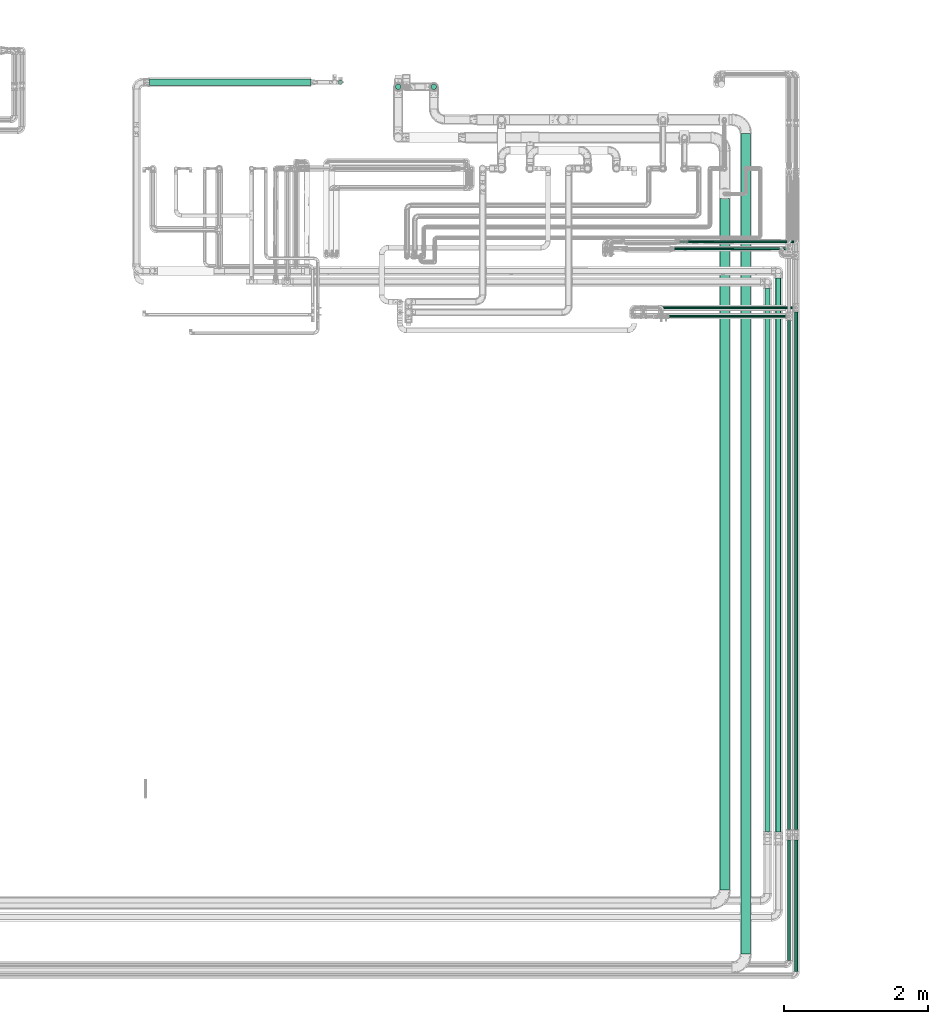
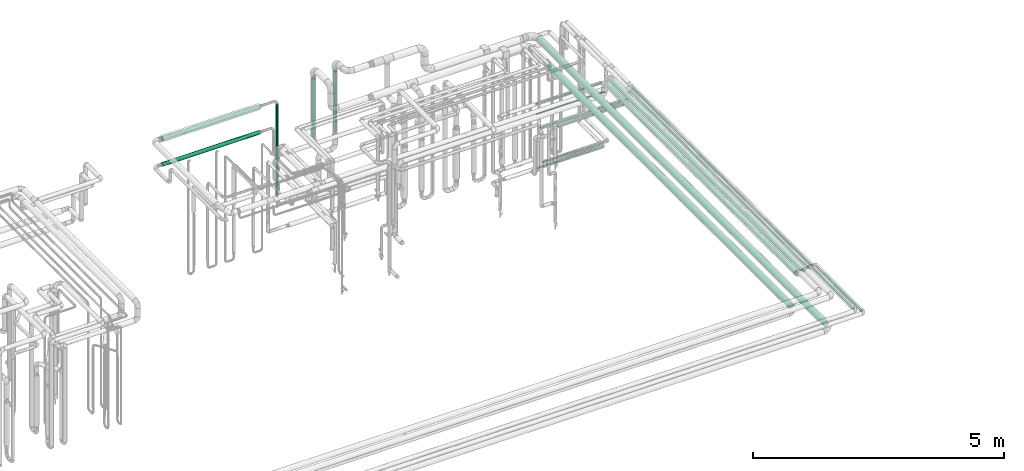
# One storey, part 543 of 827: 19 flow segments.
"""IFC2X3 building model written with IfcOpenShell, lengths in millimetres."""

from ifc_helpers import new_model, entity, si_unit, converted_unit, derived_unit, direction, frame, origin, origin_2d_with_axis, place, context, subcontext, project, spatial, polyline, circle, outline, extrude, type_object, element, save


model = new_model("IFC2X3")

# Units and contexts
model_context = context("Model", 3, precision=0.01, world=origin(), true_north=direction((6.12303176911189e-17, 1.0)))
body_context = subcontext(model_context, "Body", "Model", "MODEL_VIEW")
ifc_project = project(units=[si_unit("LENGTHUNIT", "METRE", prefix="MILLI"), si_unit("AREAUNIT", "SQUARE_METRE"), si_unit("VOLUMEUNIT", "CUBIC_METRE"), converted_unit("PLANEANGLEUNIT", "DEGREE", entity("IfcRatioMeasure", 0.0174532925199433), si_unit("PLANEANGLEUNIT", "RADIAN"), dimensions=[0, 0, 0, 0, 0, 0, 0]), si_unit("MASSUNIT", "GRAM", prefix="KILO"), derived_unit("MASSDENSITYUNIT", [(si_unit("MASSUNIT", "GRAM", prefix="KILO"), 1), (si_unit("LENGTHUNIT", "METRE"), -3)]), derived_unit("MOMENTOFINERTIAUNIT", [(si_unit("LENGTHUNIT", "METRE"), 4)]), si_unit("TIMEUNIT", "SECOND"), si_unit("FREQUENCYUNIT", "HERTZ"), si_unit("THERMODYNAMICTEMPERATUREUNIT", "DEGREE_CELSIUS"), derived_unit("THERMALTRANSMITTANCEUNIT", [(si_unit("MASSUNIT", "GRAM", prefix="KILO"), 1), (si_unit("THERMODYNAMICTEMPERATUREUNIT", "KELVIN"), -1), (si_unit("TIMEUNIT", "SECOND"), -3)]), derived_unit("VOLUMETRICFLOWRATEUNIT", [(si_unit("LENGTHUNIT", "METRE"), 3), (si_unit("TIMEUNIT", "SECOND"), -1)]), derived_unit("MASSFLOWRATEUNIT", [(si_unit("MASSUNIT", "GRAM", prefix="KILO"), 1), (si_unit("TIMEUNIT", "SECOND"), -1)]), derived_unit("ROTATIONALFREQUENCYUNIT", [(si_unit("TIMEUNIT", "SECOND"), -1)]), si_unit("ELECTRICCURRENTUNIT", "AMPERE"), si_unit("ELECTRICVOLTAGEUNIT", "VOLT"), si_unit("POWERUNIT", "WATT"), si_unit("FORCEUNIT", "NEWTON", prefix="KILO"), si_unit("ILLUMINANCEUNIT", "LUX"), si_unit("LUMINOUSFLUXUNIT", "LUMEN"), si_unit("LUMINOUSINTENSITYUNIT", "CANDELA"), derived_unit("USERDEFINED", [(si_unit("MASSUNIT", "GRAM", prefix="KILO"), -1), (si_unit("LENGTHUNIT", "METRE"), -2), (si_unit("TIMEUNIT", "SECOND"), 3), (si_unit("LUMINOUSFLUXUNIT", "LUMEN"), 1)]), derived_unit("LINEARVELOCITYUNIT", [(si_unit("LENGTHUNIT", "METRE"), 1), (si_unit("TIMEUNIT", "SECOND"), -1)]), si_unit("PRESSUREUNIT", "PASCAL"), derived_unit("USERDEFINED", [(si_unit("LENGTHUNIT", "METRE"), -2), (si_unit("MASSUNIT", "GRAM", prefix="KILO"), 1), (si_unit("TIMEUNIT", "SECOND"), -2)]), derived_unit("LINEARFORCEUNIT", [(si_unit("MASSUNIT", "GRAM", prefix="KILO"), 1), (si_unit("LENGTHUNIT", "METRE"), 1), (si_unit("TIMEUNIT", "SECOND"), -2), (si_unit("LENGTHUNIT", "METRE"), -1)]), derived_unit("PLANARFORCEUNIT", [(si_unit("MASSUNIT", "GRAM", prefix="KILO"), 1), (si_unit("LENGTHUNIT", "METRE"), 1), (si_unit("TIMEUNIT", "SECOND"), -2), (si_unit("LENGTHUNIT", "METRE"), -2)])], contexts=[model_context])

# Site, building, storey
site_placement = place(None, origin())
site = spatial("IfcSite", under=ifc_project, at=site_placement, CompositionType="ELEMENT")
building_placement = place(site_placement, origin())
building = spatial("IfcBuilding", under=site, at=building_placement, CompositionType="ELEMENT")
storey_placement = place(building_placement, frame((0.0, 0.0, 28200.0)))
storey = spatial("IfcBuildingStorey", under=building, at=storey_placement, Name="08", CompositionType="ELEMENT", Elevation=28200.0)

# Flow segments
pipe_segment_type_1 = type_object("IfcPipeSegmentType", PredefinedType="NOTDEFINED")
flow_segment_1_placement = place(storey_placement, frame((60382.95, 6565.0, 2831.9)))
element("IfcFlowSegment", 1, at=flow_segment_1_placement, inside=storey, type_object=pipe_segment_type_1, context=body_context, shape_type="SweptSolid", body=[
    extrude(circle(Radius=66.5, at=origin_2d_with_axis()), frame((68.1, 0.0, 68.1), z_axis=(0.0, 1.0, 0.0), x_axis=(-1.0, 0.0, 0.0)), (0.0, 0.0, 1.0), 11425.0955266224),
])
flow_segment_2_placement = place(storey_placement, frame((60090.45, 7456.2, 2831.87)))
element("IfcFlowSegment", 2, at=flow_segment_2_placement, inside=storey, type_object=pipe_segment_type_1, context=body_context, shape_type="SweptSolid", body=[
    extrude(circle(Radius=66.5, at=origin_2d_with_axis()), frame((68.1, 0.0, 68.1), z_axis=(0.0, 1.0, 0.0), x_axis=(-1.0, 0.0, 0.0)), (0.0, 0.0, 1.0), 9626.5836518491),
])
flow_segment_3_placement = place(storey_placement, frame((56068.95, 18596.39, 1800.0)))
element("IfcFlowSegment", 3, at=flow_segment_3_placement, inside=storey, type_object=pipe_segment_type_1, context=body_context, shape_type="SweptSolid", body=[
    extrude(circle(Radius=38.0, at=origin_2d_with_axis()), frame((39.6, 39.6, 0.0)), (0.0, 0.0, 1.0), 1469.74318880571),
])
flow_segment_4_placement = place(storey_placement, frame((55571.45, 18596.39, 1843.17)))
element("IfcFlowSegment", 4, at=flow_segment_4_placement, inside=storey, type_object=pipe_segment_type_1, context=body_context, shape_type="SweptSolid", body=[
    extrude(circle(Radius=38.0, at=origin_2d_with_axis()), frame((39.6, 39.6, 0.0)), (0.0, 0.0, 1.0), 1426.57392214822),
])
pipe_segment_type_2 = type_object("IfcPipeSegmentType", PredefinedType="NOTDEFINED")
flow_segment_5_placement = place(storey_placement, frame((61127.04, 8300.34, 2974.15)))
element("IfcFlowSegment", 5, at=flow_segment_5_placement, inside=storey, type_object=pipe_segment_type_2, context=body_context, shape_type="SweptSolid", body=[
    extrude(circle(Radius=24.0, at=origin_2d_with_axis()), frame((25.6, 0.0, 25.6), z_axis=(0.0, 1.0, 0.0), x_axis=(-1.0, 0.0, 0.0)), (0.0, 0.0, 1.0), 7203.18637121827),
])
flow_segment_6_placement = place(storey_placement, frame((61027.04, 8301.25, 2974.15)))
element("IfcFlowSegment", 6, at=flow_segment_6_placement, inside=storey, type_object=pipe_segment_type_2, context=body_context, shape_type="SweptSolid", body=[
    extrude(circle(Radius=24.0, at=origin_2d_with_axis()), frame((25.6, 0.0, 25.6), z_axis=(0.0, 1.0, 0.0), x_axis=(-1.0, 0.0, 0.0)), (0.0, 0.0, 1.0), 7085.96306405012),
])
flow_segment_7_placement = place(storey_placement, frame((59460.44, 16364.84, 2635.0)))
element("IfcFlowSegment", 7, at=flow_segment_7_placement, inside=storey, type_object=pipe_segment_type_2, context=body_context, shape_type="SweptSolid", body=[
    extrude(circle(Radius=13.4, at=origin_2d_with_axis()), frame((0.0, 15.0, 15.0), z_axis=(1.0, 0.0, 0.0), x_axis=(0.0, 1.0, 0.0)), (0.0, 0.0, 1.0), 1458.10267850027),
])
flow_segment_8_placement = place(storey_placement, frame((59449.82, 16364.84, 2384.94)))
element("IfcFlowSegment", 8, at=flow_segment_8_placement, inside=storey, type_object=pipe_segment_type_2, context=body_context, shape_type="SweptSolid", body=[
    extrude(circle(Radius=13.4, at=origin_2d_with_axis()), frame((0.0, 15.0, 15.0), z_axis=(1.0, 0.0, 0.0), x_axis=(0.0, 1.0, 0.0)), (0.0, 0.0, 1.0), 1573.71570923954),
])
flow_segment_9_placement = place(storey_placement, frame((59642.96, 16464.66, 1085.0)))
element("IfcFlowSegment", 9, at=flow_segment_9_placement, inside=storey, type_object=pipe_segment_type_2, context=body_context, shape_type="SweptSolid", body=[
    extrude(circle(Radius=13.4, at=origin_2d_with_axis()), frame((0.0, 15.0, 15.0), z_axis=(1.0, 0.0, 0.0), x_axis=(0.0, 1.0, 0.0)), (0.0, 0.0, 1.0), 1480.57608503843),
])
flow_segment_10_placement = place(storey_placement, frame((59532.64, 16464.16, 985.01)))
element("IfcFlowSegment", 10, at=flow_segment_10_placement, inside=storey, type_object=pipe_segment_type_2, context=body_context, shape_type="SweptSolid", body=[
    extrude(outline(polyline([(-1.75, -13.29), (1.75, -13.29), (5.13, -12.38), (8.16, -10.63), (10.63, -8.16), (12.38, -5.13), (13.29, -1.75), (13.29, 1.75), (12.38, 5.13), (10.63, 8.16), (8.16, 10.63), (5.13, 12.38), (1.75, 13.29), (-1.75, 13.29), (-5.13, 12.38), (-8.16, 10.63), (-10.63, 8.16), (-12.38, 5.13), (-13.29, 1.75), (-13.29, -1.75), (-12.38, -5.13), (-10.63, -8.16), (-8.16, -10.63), (-5.13, -12.38), (-1.75, -13.29)])), frame((0.0, 15.0, 15.0), z_axis=(1.0, 2.5360375665644e-09, 6.76022319089879e-06), x_axis=(-6.70205752503016e-06, -0.130526192219638, 0.991444861351212)), (0.0, 0.0, 1.0), 1490.90000003478),
])
flow_segment_11_placement = place(storey_placement, frame((59063.14, 15542.18, 2681.65)))
element("IfcFlowSegment", 11, at=flow_segment_11_placement, inside=storey, type_object=pipe_segment_type_2, context=body_context, shape_type="SweptSolid", body=[
    extrude(circle(Radius=16.75, at=origin_2d_with_axis()), frame((0.0, 18.35, 18.35), z_axis=(1.0, 0.0, 0.0), x_axis=(0.0, -1.0, 0.0)), (0.0, 0.0, 1.0), 2051.50000000003),
])
flow_segment_12_placement = place(storey_placement, frame((59378.46, 15425.86, 2681.65)))
element("IfcFlowSegment", 12, at=flow_segment_12_placement, inside=storey, type_object=pipe_segment_type_2, context=body_context, shape_type="SweptSolid", body=[
    extrude(circle(Radius=16.75, at=origin_2d_with_axis()), frame((0.0, 18.35, 18.35), z_axis=(1.0, 0.0, 0.0), x_axis=(0.0, 1.0, 0.0)), (0.0, 0.0, 1.0), 1636.17726238864),
])
flow_segment_13_placement = place(storey_placement, frame((60863.76, 8260.54, 2960.65)))
element("IfcFlowSegment", 13, at=flow_segment_13_placement, inside=storey, type_object=pipe_segment_type_2, context=body_context, shape_type="SweptSolid", body=[
    extrude(circle(Radius=37.75, at=origin_2d_with_axis()), frame((39.35, 0.0, 39.35), z_axis=(0.0, 1.0, 0.0), x_axis=(-1.0, 0.0, 0.0)), (0.0, 0.0, 1.0), 7716.83971309857),
])
flow_segment_14_placement = place(storey_placement, frame((60713.76, 8269.36, 2960.65)))
element("IfcFlowSegment", 14, at=flow_segment_14_placement, inside=storey, type_object=pipe_segment_type_2, context=body_context, shape_type="SweptSolid", body=[
    extrude(circle(Radius=37.75, at=origin_2d_with_axis()), frame((39.35, 0.0, 39.35), z_axis=(0.0, 1.0, 0.0), x_axis=(-1.0, 0.0, 0.0)), (0.0, 0.0, 1.0), 7558.01289309862),
])
flow_segment_15_placement = place(storey_placement, frame((54776.47, 18668.61, 605.5)))
element("IfcFlowSegment", 15, at=flow_segment_15_placement, inside=storey, type_object=pipe_segment_type_2, context=body_context, shape_type="SweptSolid", body=[
    extrude(circle(Radius=30.0, at=origin_2d_with_axis()), frame((31.6, 31.6, 0.0)), (0.0, 0.0, 1.0), 2269.5),
])
flow_segment_16_placement = place(storey_placement, frame((52152.37, 18654.36, 2904.15)))
element("IfcFlowSegment", 16, at=flow_segment_16_placement, inside=storey, type_object=pipe_segment_type_2, context=body_context, shape_type="SweptSolid", body=[
    extrude(circle(Radius=44.25, at=origin_2d_with_axis()), frame((0.0, 45.85, 45.85), z_axis=(1.0, 0.0, 0.0), x_axis=(0.0, -1.0, 0.0)), (0.0, 0.0, 1.0), 2246.69347010136),
])
flow_segment_17_placement = place(storey_placement, frame((52152.1, 18654.36, 2274.15)))
element("IfcFlowSegment", 17, at=flow_segment_17_placement, inside=storey, type_object=pipe_segment_type_2, context=body_context, shape_type="SweptSolid", body=[
    extrude(circle(Radius=44.25, at=origin_2d_with_axis()), frame((0.0, 45.85, 45.85), z_axis=(1.0, 0.0, 0.0), x_axis=(0.0, 1.0, 0.0)), (0.0, 0.0, 1.0), 2246.96522010135),
])
flow_segment_18_placement = place(storey_placement, frame((61127.04, 6322.71, 3074.4)))
element("IfcFlowSegment", 18, at=flow_segment_18_placement, inside=storey, type_object=pipe_segment_type_2, context=body_context, shape_type="SweptSolid", body=[
    extrude(circle(Radius=24.0, at=origin_2d_with_axis()), frame((25.6, 0.0, 25.6), z_axis=(0.0, 1.0, 0.0), x_axis=(1.0, 0.0, 0.0)), (0.0, 0.0, 1.0), 1830.15099200396),
])
flow_segment_19_placement = place(storey_placement, frame((61027.04, 6473.57, 3074.4)))
element("IfcFlowSegment", 19, at=flow_segment_19_placement, inside=storey, type_object=pipe_segment_type_2, context=body_context, shape_type="SweptSolid", body=[
    extrude(circle(Radius=24.0, at=origin_2d_with_axis()), frame((25.6, 0.0, 25.6), z_axis=(0.0, 1.0, 0.0), x_axis=(1.0, 0.0, 0.0)), (0.0, 0.0, 1.0), 1680.20036242837),
])

save(model, "model.ifc")
